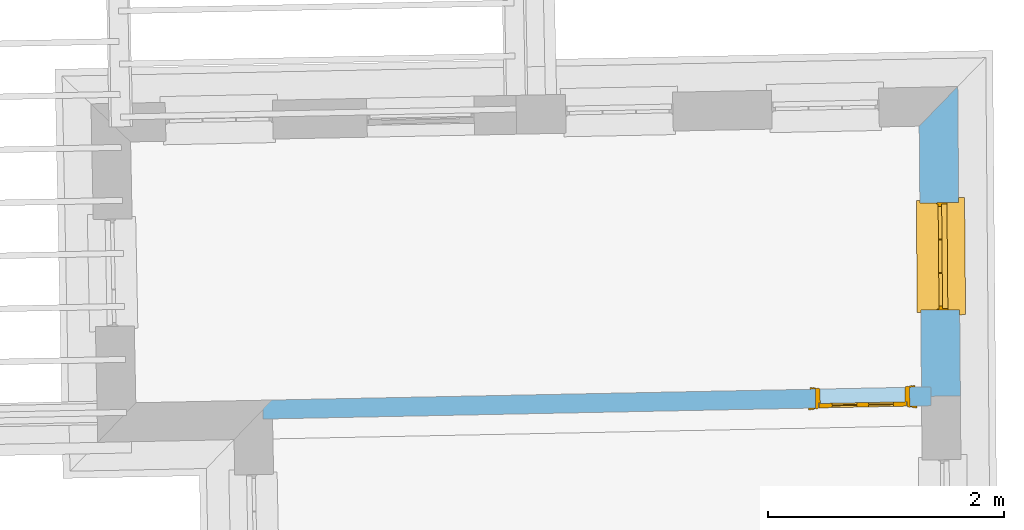
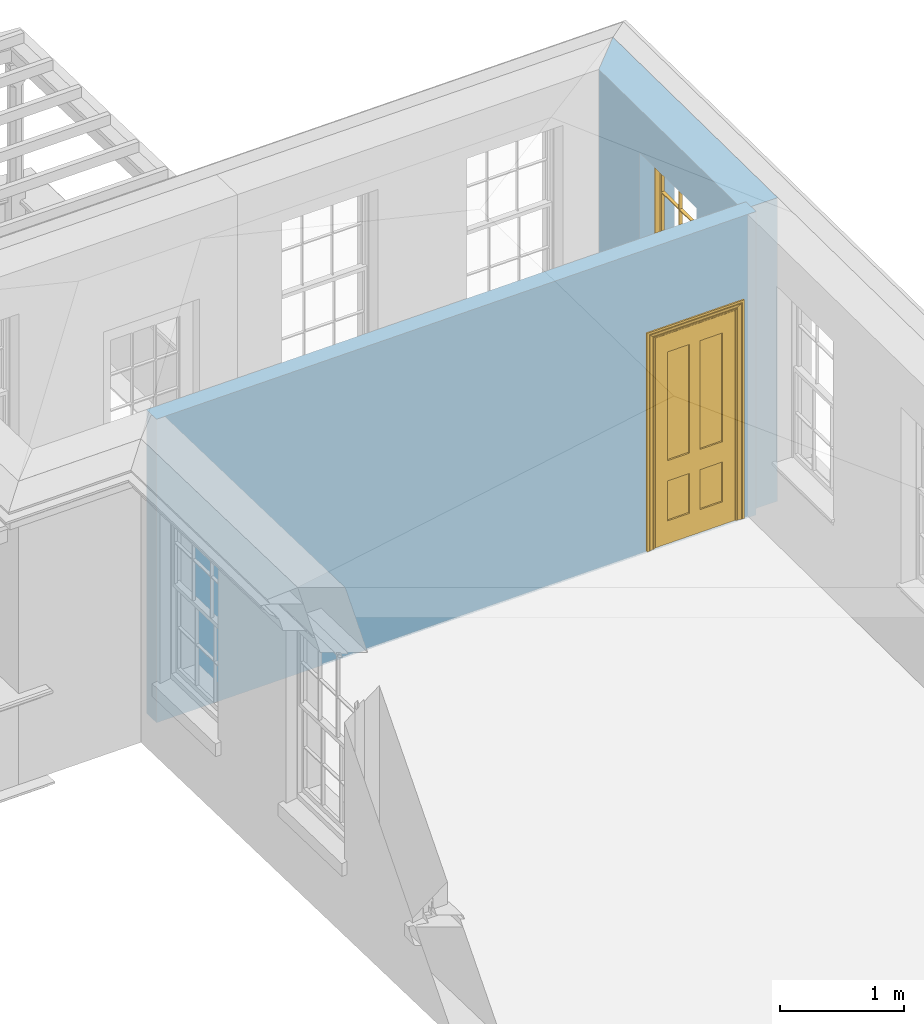
# One storey, part 8 of 11: 1 door, 1 window, 2 openings, plus 2 elements that do not belong to this part.
"""IFC2X3 building model written with IfcOpenShell, lengths in metres."""

from ifc_helpers import new_model, si_unit, frame, origin, place, context, subcontext, project, spatial, polyline, outline, extrude, faceted_brep, material, layer, layer_set, layer_usage, element, fill, save


model = new_model("IFC2X3")

# Units and contexts
model_context = context("Model", 3, world=origin())
body_context = subcontext(model_context, "Body", "Model", "MODEL_VIEW")
ifc_project = project(units=[si_unit("PLANEANGLEUNIT", "RADIAN"), si_unit("MASSUNIT", "GRAM", prefix="KILO"), si_unit("FORCEUNIT", "NEWTON", prefix="KILO"), si_unit("LENGTHUNIT", "METRE")], contexts=[model_context])

# Site, building, storey
site_placement = place(None, origin())
site = spatial("IfcSite", under=ifc_project, at=site_placement, CompositionType="ELEMENT")
building_placement = place(None, origin())
building = spatial("IfcBuilding", under=site, at=building_placement, Name="Building plot-11", CompositionType="ELEMENT")
storey_placement = place(None, frame((0.0, 0.0, 5.3)))
storey = spatial("IfcBuildingStorey", under=building, at=storey_placement, Name="Floor 1", CompositionType="ELEMENT", Elevation=5.3)

# Wall, opening, window
ifc_material_1 = material(Name="Masonry")
ifc_layer_1 = layer(ifc_material_1, 0.33, ventilated=False)
ifc_layer_set_1 = layer_set([ifc_layer_1], Name="My Wall")
ifc_layer_usage_1 = layer_usage(ifc_layer_set_1, "AXIS2", "NEGATIVE", 0.08)
wall_1_placement = place(storey_placement, origin())
wall_1 = element("IfcWallStandardCase", 1, at=wall_1_placement, inside=storey, material=ifc_layer_usage_1, Name="exterior", context=body_context, shape_type="SweptSolid", body=[
    extrude(outline(polyline([(65.5134549604276, 20.4250839832172), (65.8434428524129, 20.4279108442136), (65.820935630786, 23.0552457674694), (65.4938070899396, 22.718638343531), (65.5134549604276, 20.4250839832172)])), origin(), (0.0, 0.0, 1.0), 3.0),
])
opening_1_placement = place(storey_placement, frame((0.0, 0.0, 0.75)))
opening_1 = element("IfcOpeningElement", 2, at=opening_1_placement, cuts=wall_1, Name="Opening", ObjectType="Opening", context=body_context, shape_type="SweptSolid", body=[
    extrude(outline(polyline([(65.8371699708289, 21.1601629688085), (65.8293746874752, 22.0701295800407), (65.4993867954899, 22.0673027190443), (65.5071820788436, 21.157336107812), (65.8371699708289, 21.1601629688085)])), origin(), (0.0, 0.0, 1.0), 1.82),
])
window_placement = place(storey_placement, frame((65.5871791435673, 21.1580214074475, 0.75), z_axis=(0.0, 0.0, 1.0), x_axis=(-0.00779528335375801, 0.909966611232214, 0.0)))
window = element("IfcWindow", 3, at=window_placement, inside=storey, Name="circulation outside window", OverallHeight=1.82, OverallWidth=0.91, context=body_context, shape_type="Brep", held_by="IfcProductRepresentation", body=[
    faceted_brep([(0.033125, -0.105, 0.975209), (0.01, -0.105, 0.975209), (0.033125, -0.105, 1.376042), (0.876875, -0.105, 0.975209), (0.876875, -0.105, 1.376042), (0.9, -0.105, 0.975209), (0.876875, -0.105, 1.386042), (0.876875, -0.105, 1.786875), (0.9, -0.105, 1.81), (0.033125, -0.105, 1.786875), (0.033125, -0.105, 1.386042), (0.01, -0.105, 1.81), (0.876875, -0.135, 1.376042), (0.876875, -0.135, 0.975209), (0.9, -0.135, 0.937083), (0.033125, -0.135, 1.786875), (0.01, -0.135, 1.81), (0.033125, -0.135, 1.386042), (0.01, -0.135, 0.937083), (0.033125, -0.135, 0.975209), (0.033125, -0.135, 1.376042), (0.876875, -0.135, 1.786875), (0.876875, -0.135, 1.386042), (0.9, -0.135, 1.81), (0.033125, -0.105, 0.937083), (0.01, -0.105, 0.937083), (0.033125, -0.105, 0.53625), (0.876875, -0.105, 0.937083), (0.876875, -0.105, 0.53625), (0.9, -0.105, 0.937083), (0.876875, -0.105, 0.52625), (0.876875, -0.105, 0.125417), (0.9, -0.105, 0.077167), (0.033125, -0.105, 0.125417), (0.033125, -0.105, 0.52625), (0.01, -0.105, 0.077167), (-0.0425, -0.25, 0.01), (-0.0425, -0.3, 0.001667), (0.0, -0.25, 0.01), (0.9525, -0.25, 0.01), (0.91, -0.25, 0.01), (0.9525, -0.3, 0.001667), (-0.02, 0.08, 0.077167), (0.0, 0.08, 0.077167), (-0.02, 0.11, 0.077167), (0.0, -0.06, 0.077167), (0.01, -0.06, 0.077167), (0.91, -0.06, 0.077167), (0.91, 0.08, 0.077167), (0.9, -0.06, 0.077167), (0.93, 0.08, 0.077167), (0.93, 0.11, 0.077167), (0.01, -0.075, 0.975209), (0.9, -0.075, 0.975209), (0.876875, -0.075, 0.125417), (0.876875, -0.075, 0.52625), (0.9, -0.075, 0.077167), (0.876875, -0.075, 0.53625), (0.876875, -0.075, 0.937083), (0.033125, -0.075, 0.125417), (0.01, -0.075, 0.077167), (0.033125, -0.075, 0.52625), (0.033125, -0.075, 0.937083), (0.033125, -0.075, 0.53625), (-0.02, 0.08, 0.052167), (-0.02, 0.11, 0.052167), (0.93, 0.11, 0.052167), (0.93, 0.08, 0.052167), (0.91, 0.08, 0.052167), (0.0, 0.08, 0.052167), (0.91, -0.15, 0.026667), (0.0, -0.15, 0.026667), (-0.0425, -0.3, -0.123333), (0.9525, -0.3, -0.123333), (-0.0425, -0.25, -0.123333), (0.9525, -0.25, -0.123333), (0.01, -0.06, 1.81), (0.9, -0.06, 1.81), (0.0, -0.06, 1.82), (0.91, -0.06, 1.82), (0.01, -0.15, 0.077167), (0.9, -0.15, 0.077167), (0.592292, -0.105, 0.125417), (0.592292, -0.075, 0.125417), (0.317708, -0.075, 0.125417), (0.317708, -0.105, 0.125417), (0.592292, -0.105, 0.53625), (0.317708, -0.105, 0.53625), (0.317708, -0.105, 0.52625), (0.592292, -0.105, 0.52625), (0.592292, -0.075, 0.53625), (0.317708, -0.075, 0.53625), (0.592292, -0.135, 1.386042), (0.592292, -0.105, 1.386042), (0.317708, -0.105, 1.386042), (0.317708, -0.135, 1.386042), (0.317708, -0.135, 1.376042), (0.592292, -0.135, 1.376042), (0.317708, -0.105, 1.376042), (0.592292, -0.105, 1.376042), (0.602292, -0.135, 1.376042), (0.592292, -0.135, 0.975209), (0.602292, -0.135, 0.975209), (0.602292, -0.105, 0.975209), (0.592292, -0.105, 0.975209), (0.602292, -0.105, 1.376042), (0.602292, -0.075, 0.53625), (0.602292, -0.105, 0.53625), (0.317708, -0.075, 0.52625), (0.307708, -0.075, 0.125417), (0.307708, -0.075, 0.52625), (0.602292, -0.075, 0.52625), (0.602292, -0.075, 0.125417), (0.592292, -0.075, 0.52625), (0.307708, -0.075, 0.53625), (0.317708, -0.075, 0.937083), (0.307708, -0.075, 0.937083), (0.602292, -0.075, 0.937083), (0.592292, -0.075, 0.937083), (0.307708, -0.105, 0.52625), (0.307708, -0.105, 0.125417), (0.307708, -0.105, 0.53625), (0.307708, -0.105, 0.937083), (0.592292, -0.105, 0.937083), (0.317708, -0.105, 0.937083), (0.602292, -0.105, 0.937083), (0.602292, -0.105, 0.52625), (0.602292, -0.105, 0.125417), (0.307708, -0.135, 1.386042), (0.307708, -0.135, 1.376042), (0.307708, -0.135, 0.975209), (0.317708, -0.135, 0.975209), (0.317708, -0.135, 1.786875), (0.307708, -0.135, 1.786875), (0.602292, -0.135, 1.786875), (0.592292, -0.135, 1.786875), (0.602292, -0.135, 1.386042), (0.602292, -0.105, 1.386042), (0.307708, -0.105, 1.386042), (0.307708, -0.105, 1.786875), (0.317708, -0.105, 1.786875), (0.592292, -0.105, 1.786875), (0.602292, -0.105, 1.786875), (0.307708, -0.105, 1.376042), (0.317708, -0.105, 0.975209), (0.307708, -0.105, 0.975209), (0.91, -0.15, 1.82), (0.9, -0.15, 1.81), (0.01, -0.15, 1.81), (0.0, -0.15, 1.82), (0.91, -0.25, 0.0), (0.0, -0.25, 0.0), (0.91, 0.08, 0.0), (0.0, 0.08, 0.0)], [[[0, 1, 2]], [[3, 4, 5]], [[6, 7, 8]], [[9, 10, 11]], [[12, 13, 14]], [[15, 16, 17]], [[18, 19, 20]], [[21, 22, 23]], [[24, 25, 26]], [[27, 28, 29]], [[30, 31, 32]], [[33, 34, 35]], [[14, 27, 29]], [[25, 24, 18]], [[36, 37, 38]], [[39, 40, 41]], [[42, 43, 44]], [[45, 46, 43]], [[47, 48, 49]], [[50, 51, 48]], [[1, 0, 52]], [[5, 53, 3]], [[54, 55, 56]], [[57, 58, 53]], [[59, 60, 61]], [[62, 63, 52]], [[48, 43, 46, 49]], [[51, 44, 43, 48]], [[64, 42, 44, 65]], [[65, 44, 51, 66]], [[66, 51, 50, 67]], [[65, 66, 68, 69]], [[60, 56, 49, 46]], [[70, 71, 38, 40]], [[37, 41, 40, 38]], [[37, 72, 73, 41]], [[74, 75, 73, 72]], [[8, 11, 76, 77]], [[76, 78, 79, 77]], [[32, 35, 80, 81]], [[81, 80, 71, 70]], [[82, 83, 84, 85]], [[86, 87, 88, 89]], [[86, 90, 91, 87]], [[92, 93, 94, 95]], [[92, 95, 96, 97]], [[96, 98, 99, 97]], [[100, 97, 101, 102]], [[103, 104, 99, 105]], [[97, 99, 104, 101]], [[102, 103, 105, 100]], [[28, 57, 106, 107]], [[108, 84, 109, 110]], [[111, 112, 83, 113]], [[114, 110, 61, 63]], [[90, 113, 108, 91]], [[115, 91, 114, 116]], [[117, 106, 90, 118]], [[111, 106, 57, 55]], [[119, 110, 109, 120]], [[34, 61, 110, 119]], [[89, 113, 83, 82]], [[88, 108, 113, 89]], [[85, 84, 108, 88]], [[121, 114, 63, 26]], [[122, 116, 114, 121]], [[123, 118, 90, 86]], [[87, 91, 115, 124]], [[107, 106, 117, 125]], [[126, 111, 55, 30]], [[127, 112, 111, 126]], [[126, 30, 28, 107]], [[88, 119, 120, 85]], [[126, 89, 82, 127]], [[125, 123, 86, 107]], [[121, 26, 34, 119]], [[124, 122, 121, 87]], [[128, 17, 20, 129]], [[96, 129, 130, 131]], [[132, 133, 128, 95]], [[134, 135, 92, 136]], [[100, 12, 22, 136]], [[137, 6, 4, 105]], [[94, 138, 139, 140]], [[137, 93, 141, 142]], [[99, 98, 94, 93]], [[143, 2, 10, 138]], [[144, 145, 143, 98]], [[129, 143, 145, 130]], [[20, 2, 143, 129]], [[131, 144, 98, 96]], [[128, 138, 10, 17]], [[133, 139, 138, 128]], [[135, 141, 93, 92]], [[95, 94, 140, 132]], [[22, 6, 137, 136]], [[136, 137, 142, 134]], [[100, 105, 4, 12]], [[107, 86, 89, 126]], [[106, 111, 113, 90]], [[91, 108, 110, 114]], [[87, 121, 119, 88]], [[97, 100, 136, 92]], [[129, 96, 95, 128]], [[98, 143, 138, 94]], [[105, 99, 93, 137]], [[131, 101, 104, 144]], [[124, 115, 118, 123]], [[132, 140, 141, 135]], [[120, 109, 59, 33]], [[15, 9, 139, 133]], [[134, 142, 7, 21]], [[31, 54, 112, 127]], [[36, 74, 72, 37]], [[39, 41, 73, 75]], [[18, 14, 101, 131]], [[23, 16, 132, 135]], [[83, 56, 60, 84]], [[52, 53, 118, 115]], [[53, 52, 144, 104]], [[11, 8, 141, 140]], [[14, 18, 124, 123]], [[2, 1, 11, 10]], [[8, 5, 4, 6]], [[57, 53, 56, 55]], [[60, 52, 63, 61]], [[26, 25, 35, 34]], [[32, 29, 28, 30]], [[14, 23, 22, 12]], [[18, 20, 17, 16]], [[19, 0, 2, 20]], [[17, 10, 9, 15]], [[12, 4, 3, 13]], [[21, 7, 6, 22]], [[27, 58, 57, 28]], [[30, 55, 54, 31]], [[33, 59, 61, 34]], [[26, 63, 62, 24]], [[5, 8, 77, 53]], [[76, 11, 1, 52]], [[46, 45, 78, 76]], [[49, 77, 79, 47]], [[70, 146, 147, 81]], [[71, 80, 148, 149]], [[19, 130, 145, 0]], [[102, 13, 3, 103]], [[116, 122, 24, 62]], [[29, 32, 81, 14]], [[80, 35, 25, 18]], [[60, 46, 76, 52]], [[77, 49, 56, 53]], [[23, 14, 81, 147]], [[16, 148, 80, 18]], [[35, 85, 120]], [[120, 33, 35]], [[127, 82, 32]], [[32, 31, 127]], [[32, 82, 85, 35]], [[102, 101, 14]], [[14, 13, 102]], [[18, 131, 130]], [[130, 19, 18]], [[134, 21, 23]], [[23, 135, 134]], [[16, 15, 133]], [[133, 132, 16]], [[11, 140, 139]], [[139, 9, 11]], [[142, 141, 8]], [[8, 7, 142]], [[23, 147, 148, 16]], [[146, 149, 148, 147]], [[52, 115, 116]], [[116, 62, 52]], [[118, 53, 117]], [[58, 117, 53]], [[27, 125, 117, 58]], [[56, 83, 112]], [[112, 54, 56]], [[109, 84, 60]], [[60, 59, 109]], [[125, 27, 14]], [[14, 123, 125]], [[122, 124, 18]], [[18, 24, 122]], [[145, 144, 52]], [[52, 0, 145]], [[103, 3, 53]], [[53, 104, 103]], [[79, 78, 149, 146]], [[78, 45, 71, 149]], [[146, 70, 47, 79]], [[150, 75, 74, 151]], [[68, 66, 67]], [[48, 68, 67, 50]], [[69, 64, 65]], [[42, 64, 69, 43]], [[69, 68, 152, 153]], [[70, 68, 48, 47]], [[150, 152, 68, 70]], [[43, 69, 71, 45]], [[69, 153, 151, 71]], [[152, 150, 151, 153]], [[38, 151, 74, 36]], [[71, 151, 38]], [[39, 75, 150, 40]], [[40, 150, 70]]]),
])
fill(opening_1, window)

# Wall, opening, door
ifc_material_2 = material(Name="Masonry")
ifc_layer_2 = layer(ifc_material_2, 0.16, ventilated=False)
ifc_layer_set_2 = layer_set([ifc_layer_2], Name="My Wall")
ifc_layer_usage_2 = layer_usage(ifc_layer_set_2, "AXIS2", "NEGATIVE", 0.08)
wall_2_placement = place(storey_placement, origin())
wall_2 = element("IfcWallStandardCase", 4, at=wall_2_placement, inside=storey, material=ifc_layer_usage_2, Name="interior", context=body_context, shape_type="SweptSolid", body=[
    extrude(outline(polyline([(65.5950514320663, 20.3457852725911), (65.5918526182363, 20.5057532931143), (59.9213239847482, 20.3923620955674), (59.9245227985782, 20.2323940750442), (65.5950514320663, 20.3457852725911)])), origin(), (0.0, 0.0, 1.0), 3.0),
])
opening_2_placement = place(storey_placement, frame((0.0, 0.0, 0.0199999999999996)))
opening_2 = element("IfcOpeningElement", 5, at=opening_2_placement, cuts=wall_2, Name="Opening", ObjectType="Opening", context=body_context, shape_type="SweptSolid", body=[
    extrude(outline(polyline([(65.4118885951478, 20.5021546275555), (64.6120484925323, 20.4861605584054), (64.6152473063623, 20.3261925378823), (65.4150874089778, 20.3421866070324), (65.4118885951478, 20.5021546275555)])), origin(), (0.0, 0.0, 1.0), 2.1),
])
door_placement = place(storey_placement, frame((65.4134880020628, 20.4221706172939, 0.0199999999999996), z_axis=(0.0, 0.0, 1.0), x_axis=(-0.799840102615534, -0.0159940691500964, 0.0)))
door = element("IfcDoor", 6, at=door_placement, inside=storey, Name="bedroom inside door", OverallHeight=2.1, OverallWidth=0.8, context=body_context, shape_type="Brep", held_by="IfcProductRepresentation", body=[
    faceted_brep([(0.773, 0.08, 1.895), (0.66, 0.08, 1.895), (0.66, 0.08, 2.073), (0.773, 0.08, 2.073), (0.773, 0.08, 0.82), (0.66, 0.08, 0.82), (0.45, 0.08, 1.895), (0.45, 0.08, 2.073), (0.773, 0.08, 0.62), (0.66, 0.08, 0.62), (0.66, 0.065, 0.82), (0.66, 0.065, 1.895), (0.45, 0.065, 1.895), (0.35, 0.08, 1.895), (0.35, 0.08, 2.073), (0.773, 0.08, 0.225), (0.66, 0.08, 0.225), (0.45, 0.08, 0.62), (0.45, 0.08, 0.82), (0.45, 0.065, 0.82), (0.35, 0.08, 0.82), (0.14, 0.08, 2.073), (0.14, 0.08, 1.895), (0.773, 0.08, 0.0), (0.66, 0.08, 0.0), (0.66, 0.065, 0.225), (0.66, 0.065, 0.62), (0.45, 0.065, 0.62), (0.35, 0.08, 0.62), (0.35, 0.065, 0.82), (0.35, 0.065, 1.895), (0.14, 0.065, 1.895), (0.027, 0.08, 2.073), (0.027, 0.08, 1.895), (0.773, 0.042, 0.0), (0.66, 0.042, 0.0), (0.45, 0.08, 0.0), (0.45, 0.08, 0.225), (0.45, 0.065, 0.225), (0.35, 0.08, 0.225), (0.14, 0.08, 0.82), (0.14, 0.08, 0.62), (0.14, 0.065, 0.82), (0.027, 0.08, 0.82), (0.773, 0.042, 0.225), (0.66, 0.042, 0.225), (0.45, 0.042, 0.0), (0.35, 0.08, 0.0), (0.35, 0.065, 0.225), (0.35, 0.065, 0.62), (0.14, 0.065, 0.62), (0.027, 0.08, 0.62), (0.773, 0.042, 0.62), (0.66, 0.042, 0.62), (0.45, 0.042, 0.225), (0.35, 0.042, 0.0), (0.14, 0.08, 0.225), (0.14, 0.08, 0.0), (0.14, 0.065, 0.225), (0.027, 0.08, 0.225), (0.773, 0.042, 0.82), (0.66, 0.042, 0.82), (0.66, 0.057, 0.62), (0.66, 0.057, 0.225), (0.45, 0.057, 0.225), (0.35, 0.042, 0.225), (0.14, 0.042, 0.0), (0.027, 0.08, 0.0), (0.773, 0.042, 1.895), (0.66, 0.042, 1.895), (0.45, 0.042, 0.62), (0.45, 0.042, 0.82), (0.45, 0.057, 0.62), (0.35, 0.042, 0.62), (0.14, 0.042, 0.225), (0.027, 0.042, 0.0), (0.773, 0.042, 2.073), (0.66, 0.042, 2.073), (0.66, 0.057, 1.895), (0.66, 0.057, 0.82), (0.45, 0.057, 0.82), (0.35, 0.042, 0.82), (0.35, 0.057, 0.62), (0.35, 0.057, 0.225), (0.14, 0.057, 0.225), (0.027, 0.042, 0.225), (0.45, 0.042, 1.895), (0.45, 0.042, 2.073), (0.45, 0.057, 1.895), (0.35, 0.042, 1.895), (0.14, 0.042, 0.82), (0.14, 0.042, 0.62), (0.14, 0.057, 0.62), (0.027, 0.042, 0.62), (0.35, 0.042, 2.073), (0.35, 0.057, 1.895), (0.35, 0.057, 0.82), (0.14, 0.057, 0.82), (0.027, 0.042, 0.82), (0.14, 0.042, 2.073), (0.14, 0.042, 1.895), (0.14, 0.057, 1.895), (0.027, 0.042, 1.895), (0.027, 0.042, 2.073), (0.02, 0.085, 0.0), (0.005, 0.09, 0.0), (0.005, 0.09, 2.095), (0.02, 0.085, 2.08), (0.02, 0.08, 0.0), (0.0, 0.085, 0.0), (0.0, 0.085, 2.1), (0.795, 0.09, 2.095), (0.78, 0.085, 2.08), (0.02, 0.08, 2.08), (0.0, 0.08, 0.0), (-0.032, 0.095, 0.0), (-0.032, 0.095, 2.132), (0.8, 0.085, 2.1), (0.795, 0.09, 0.0), (0.78, 0.085, 0.0), (0.78, 0.08, 2.08), (0.04, 0.04, 0.0), (0.025, 0.04, 0.0), (0.025, 0.04, 2.075), (0.04, 0.04, 2.06), (-0.04, 0.09, 0.0), (-0.04, 0.09, 2.14), (0.832, 0.095, 2.132), (0.8, 0.085, 0.0), (0.78, 0.08, 0.0), (0.8, 0.08, 0.0), (0.86, 0.08, 0.0), (0.86, 0.08, 2.16), (0.8, 0.08, 2.1), (-0.06, 0.08, 2.16), (0.0, 0.08, 2.1), (-0.06, 0.08, 0.0), (-0.04, 0.095, 0.0), (-0.04, 0.095, 2.14), (0.84, 0.09, 2.14), (0.832, 0.095, 0.0), (0.84, 0.09, 0.0), (0.86, 0.095, 0.0), (0.86, 0.095, 2.16), (-0.06, 0.095, 2.16), (-0.06, 0.095, 0.0), (0.84, 0.095, 0.0), (0.84, 0.095, 2.14), (-0.025, -0.095, 0.0), (-0.025, -0.09, 0.0), (-0.025, -0.09, 2.125), (-0.025, -0.095, 2.125), (-0.017, -0.095, 0.0), (-0.017, -0.095, 2.117), (0.825, -0.09, 2.125), (0.825, -0.095, 2.125), (0.825, -0.095, 0.0), (0.845, -0.095, 0.0), (-0.045, -0.095, 2.145), (-0.045, -0.095, 0.0), (0.845, -0.095, 2.145), (0.015, -0.085, 0.0), (0.015, -0.085, 2.085), (0.817, -0.095, 2.117), (0.825, -0.09, 0.0), (0.845, -0.08, 0.0), (0.845, -0.08, 2.145), (-0.045, -0.08, 2.145), (-0.045, -0.08, 0.0), (0.02, -0.09, 0.0), (0.02, -0.09, 2.08), (0.785, -0.085, 2.085), (0.817, -0.095, 0.0), (0.8, -0.08, 0.0), (0.8, -0.08, 2.1), (0.0, -0.08, 2.1), (0.0, -0.08, 0.0), (0.035, -0.085, 0.0), (0.035, -0.085, 2.065), (0.78, -0.09, 2.08), (0.785, -0.085, 0.0), (0.775, 0.04, 2.075), (0.76, 0.04, 2.06), (0.035, -0.08, 2.065), (0.035, -0.08, 0.0), (0.765, -0.085, 2.065), (0.78, -0.09, 0.0), (0.765, -0.08, 0.0), (0.765, -0.08, 2.065), (0.765, -0.085, 0.0), (0.04, -0.08, 2.06), (0.04, -0.08, 0.0), (0.76, -0.08, 2.06), (0.76, -0.08, 0.0), (0.76, 0.04, 0.0), (0.775, 0.04, 0.0), (0.025, 0.08, 0.0), (0.025, 0.08, 2.075), (0.775, 0.08, 0.0), (0.775, 0.08, 2.075)], [[[0, 1, 2, 3]], [[1, 0, 4, 5]], [[1, 6, 7, 2]], [[8, 9, 5, 4]], [[1, 5, 10, 11]], [[6, 1, 11, 12]], [[6, 13, 14, 7]], [[15, 16, 9, 8]], [[9, 17, 18, 5]], [[5, 18, 19, 10]], [[10, 19, 12, 11]], [[18, 6, 12, 19]], [[18, 20, 13, 6]], [[21, 14, 13, 22]], [[23, 24, 16, 15]], [[9, 16, 25, 26]], [[17, 9, 26, 27]], [[17, 28, 20, 18]], [[13, 20, 29, 30]], [[22, 13, 30, 31]], [[32, 21, 22, 33]], [[34, 35, 24, 23]], [[24, 36, 37, 16]], [[16, 37, 38, 25]], [[25, 38, 27, 26]], [[37, 17, 27, 38]], [[37, 39, 28, 17]], [[40, 20, 28, 41]], [[20, 40, 42, 29]], [[31, 30, 29, 42]], [[40, 22, 31, 42]], [[33, 22, 40, 43]], [[35, 34, 44, 45]], [[35, 46, 36, 24]], [[36, 47, 39, 37]], [[28, 39, 48, 49]], [[41, 28, 49, 50]], [[43, 40, 41, 51]], [[45, 44, 52, 53]], [[46, 35, 45, 54]], [[46, 55, 47, 36]], [[56, 39, 47, 57]], [[39, 56, 58, 48]], [[50, 49, 48, 58]], [[56, 41, 50, 58]], [[51, 41, 56, 59]], [[53, 52, 60, 61]], [[45, 53, 62, 63]], [[54, 45, 63, 64]], [[55, 46, 54, 65]], [[55, 66, 57, 47]], [[59, 56, 57, 67]], [[61, 60, 68, 69]], [[70, 53, 61, 71]], [[53, 70, 72, 62]], [[72, 64, 63, 62]], [[70, 54, 64, 72]], [[65, 54, 70, 73]], [[65, 74, 66, 55]], [[67, 57, 66, 75]], [[69, 68, 76, 77]], [[61, 69, 78, 79]], [[71, 61, 79, 80]], [[73, 70, 71, 81]], [[65, 73, 82, 83]], [[74, 65, 83, 84]], [[74, 85, 75, 66]], [[86, 69, 77, 87]], [[69, 86, 88, 78]], [[88, 80, 79, 78]], [[86, 71, 80, 88]], [[81, 71, 86, 89]], [[73, 81, 90, 91]], [[73, 91, 92, 82]], [[83, 82, 92, 84]], [[91, 74, 84, 92]], [[91, 93, 85, 74]], [[89, 86, 87, 94]], [[81, 89, 95, 96]], [[90, 81, 96, 97]], [[90, 98, 93, 91]], [[94, 99, 100, 89]], [[89, 100, 101, 95]], [[101, 97, 96, 95]], [[100, 90, 97, 101]], [[100, 102, 98, 90]], [[99, 103, 102, 100]], [[32, 103, 99, 21]], [[102, 103, 32, 33]], [[98, 102, 33, 43]], [[21, 99, 94, 14]], [[94, 87, 7, 14]], [[7, 87, 77, 2]], [[76, 3, 2, 77]], [[43, 51, 93, 98]], [[51, 59, 85, 93]], [[67, 75, 85, 59]], [[34, 23, 15, 44]], [[44, 15, 8, 52]], [[52, 8, 4, 60]], [[0, 68, 60, 4]], [[0, 3, 76, 68]], [[104, 105, 106, 107]], [[104, 108, 109, 105]], [[105, 109, 110, 106]], [[107, 106, 111, 112]], [[107, 113, 108, 104]], [[114, 109, 108]], [[109, 115, 116, 110]], [[106, 110, 117, 111]], [[112, 111, 118, 119]], [[113, 107, 112, 120]], [[121, 122, 123, 124]], [[115, 109, 114, 125]], [[115, 125, 126, 116]], [[110, 116, 127, 117]], [[111, 117, 128, 118]], [[118, 128, 129, 119]], [[120, 112, 119, 129]], [[130, 129, 128]], [[130, 131, 132, 133]], [[133, 132, 134, 135]], [[135, 134, 136, 114]], [[136, 125, 114]], [[125, 137, 138, 126]], [[116, 126, 139, 127]], [[117, 127, 140, 128]], [[141, 130, 128, 140]], [[131, 130, 141]], [[131, 142, 143, 132]], [[132, 143, 144, 134]], [[134, 144, 145, 136]], [[137, 125, 136, 145]], [[143, 142, 146]], [[143, 146, 147]], [[137, 145, 144]], [[143, 147, 138]], [[138, 137, 144]], [[143, 138, 144]], [[126, 138, 147, 139]], [[127, 139, 141, 140]], [[142, 131, 141, 146]], [[139, 147, 146, 141]], [[148, 149, 150, 151]], [[149, 152, 153, 150]], [[151, 150, 154, 155]], [[155, 156, 157]], [[158, 159, 148]], [[158, 148, 151]], [[155, 157, 160]], [[158, 151, 155]], [[155, 160, 158]], [[152, 161, 162, 153]], [[150, 153, 163, 154]], [[155, 154, 164, 156]], [[156, 164, 165, 157]], [[157, 165, 166, 160]], [[160, 166, 167, 158]], [[158, 167, 168, 159]], [[161, 169, 170, 162]], [[153, 162, 171, 163]], [[154, 163, 172, 164]], [[165, 164, 173]], [[165, 173, 174, 166]], [[166, 174, 175, 167]], [[167, 175, 176, 168]], [[169, 177, 178, 170]], [[162, 170, 179, 171]], [[163, 171, 180, 172]], [[172, 180, 173, 164]], [[124, 123, 181, 182]], [[183, 178, 177, 184]], [[170, 178, 185, 179]], [[171, 179, 186, 180]], [[187, 173, 180]], [[185, 188, 187, 189]], [[188, 185, 178, 183]], [[179, 185, 189, 186]], [[189, 187, 180, 186]], [[190, 183, 184, 191]], [[192, 188, 183, 190]], [[191, 184, 122, 121]], [[124, 190, 191, 121]], [[193, 187, 188, 192]], [[182, 192, 190, 124]], [[184, 176, 122]], [[194, 195, 187, 193]], [[192, 182, 194, 193]], [[161, 176, 184]], [[114, 108, 122, 176]], [[173, 187, 195]], [[152, 149, 176, 161]], [[169, 161, 184, 177]], [[196, 122, 108]], [[176, 175, 135, 114]], [[173, 195, 129, 130]], [[176, 149, 168]], [[123, 122, 196, 197]], [[196, 108, 113, 197]], [[175, 174, 133, 135]], [[198, 129, 195]], [[133, 174, 173, 130]], [[159, 168, 149, 148]], [[181, 123, 197, 199]], [[197, 113, 120, 199]], [[199, 120, 129, 198]], [[195, 181, 199, 198]], [[195, 194, 182, 181]]]),
])
fill(opening_2, door)

save(model, "model.ifc")
